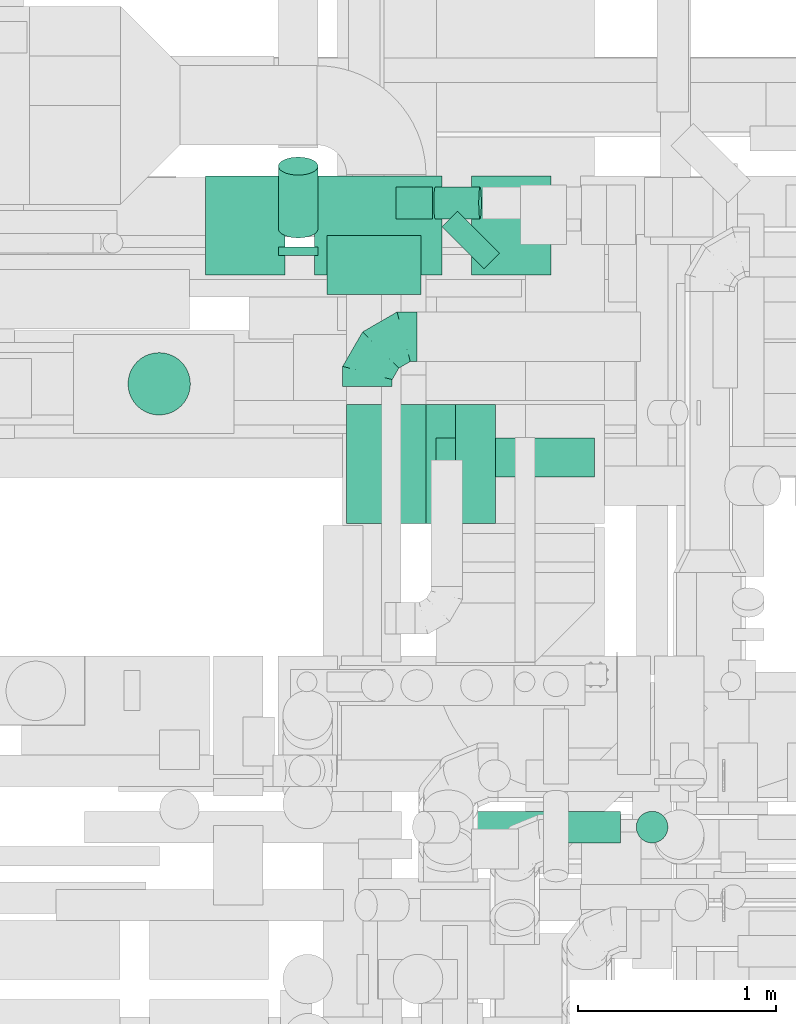
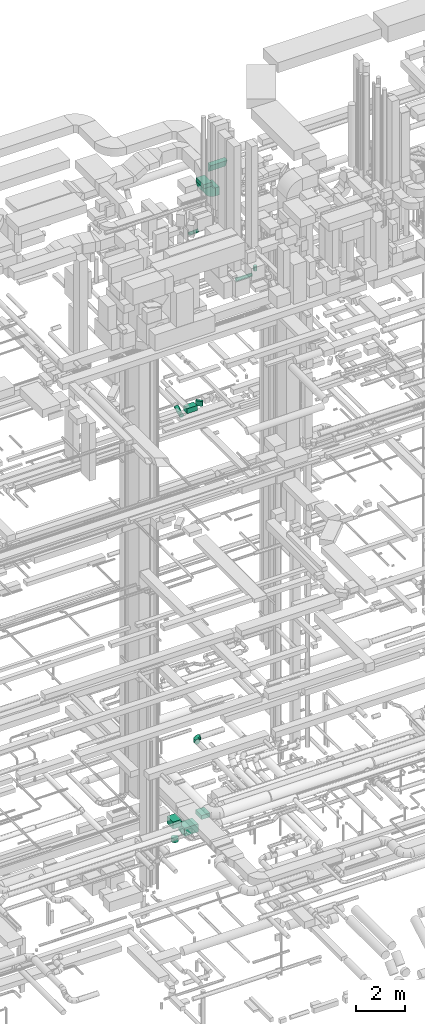
# One storey, part 192 of 337: 14 flow segments, 3 flow fittings.
"""IFC2X3 building model written with IfcOpenShell, lengths in millimetres."""

from ifc_helpers import new_model, entity, si_unit, converted_unit, derived_unit, direction, frame, frame_2d, origin, origin_2d_with_axis, place, context, subcontext, project, spatial, polyline, circle_curve, parameter, trimmed, segment, composite_curve, rectangle, circle, outline, extrude, faceted_brep, source, transform, mapped, material, type_object, type_shapes, element, save


model = new_model("IFC2X3")

# Units and contexts
model_context = context("Model", 3, precision=0.01, world=origin(), true_north=direction((6.12303176911189e-17, 1.0)))
body_context = subcontext(model_context, "Body", "Model", "MODEL_VIEW")
ifc_project = project(units=[si_unit("LENGTHUNIT", "METRE", prefix="MILLI"), si_unit("AREAUNIT", "SQUARE_METRE"), si_unit("VOLUMEUNIT", "CUBIC_METRE"), converted_unit("PLANEANGLEUNIT", "DEGREE", entity("IfcRatioMeasure", 0.0174532925199433), si_unit("PLANEANGLEUNIT", "RADIAN"), dimensions=[0, 0, 0, 0, 0, 0, 0]), si_unit("MASSUNIT", "GRAM", prefix="KILO"), derived_unit("MASSDENSITYUNIT", [(si_unit("MASSUNIT", "GRAM", prefix="KILO"), 1), (si_unit("LENGTHUNIT", "METRE"), -3)]), derived_unit("MOMENTOFINERTIAUNIT", [(si_unit("LENGTHUNIT", "METRE"), 4)]), si_unit("TIMEUNIT", "SECOND"), si_unit("FREQUENCYUNIT", "HERTZ"), si_unit("THERMODYNAMICTEMPERATUREUNIT", "DEGREE_CELSIUS"), derived_unit("THERMALTRANSMITTANCEUNIT", [(si_unit("MASSUNIT", "GRAM", prefix="KILO"), 1), (si_unit("THERMODYNAMICTEMPERATUREUNIT", "KELVIN"), -1), (si_unit("TIMEUNIT", "SECOND"), -3)]), derived_unit("VOLUMETRICFLOWRATEUNIT", [(si_unit("LENGTHUNIT", "METRE"), 3), (si_unit("TIMEUNIT", "SECOND"), -1)]), derived_unit("MASSFLOWRATEUNIT", [(si_unit("MASSUNIT", "GRAM", prefix="KILO"), 1), (si_unit("TIMEUNIT", "SECOND"), -1)]), derived_unit("ROTATIONALFREQUENCYUNIT", [(si_unit("TIMEUNIT", "SECOND"), -1)]), si_unit("ELECTRICCURRENTUNIT", "AMPERE"), si_unit("ELECTRICVOLTAGEUNIT", "VOLT"), si_unit("POWERUNIT", "WATT"), si_unit("FORCEUNIT", "NEWTON", prefix="KILO"), si_unit("ILLUMINANCEUNIT", "LUX"), si_unit("LUMINOUSFLUXUNIT", "LUMEN"), si_unit("LUMINOUSINTENSITYUNIT", "CANDELA"), derived_unit("USERDEFINED", [(si_unit("MASSUNIT", "GRAM", prefix="KILO"), -1), (si_unit("LENGTHUNIT", "METRE"), -2), (si_unit("TIMEUNIT", "SECOND"), 3), (si_unit("LUMINOUSFLUXUNIT", "LUMEN"), 1)]), derived_unit("LINEARVELOCITYUNIT", [(si_unit("LENGTHUNIT", "METRE"), 1), (si_unit("TIMEUNIT", "SECOND"), -1)]), si_unit("PRESSUREUNIT", "PASCAL"), derived_unit("USERDEFINED", [(si_unit("LENGTHUNIT", "METRE"), -2), (si_unit("MASSUNIT", "GRAM", prefix="KILO"), 1), (si_unit("TIMEUNIT", "SECOND"), -2)]), derived_unit("LINEARFORCEUNIT", [(si_unit("MASSUNIT", "GRAM", prefix="KILO"), 1), (si_unit("LENGTHUNIT", "METRE"), 1), (si_unit("TIMEUNIT", "SECOND"), -2), (si_unit("LENGTHUNIT", "METRE"), -1)]), derived_unit("PLANARFORCEUNIT", [(si_unit("MASSUNIT", "GRAM", prefix="KILO"), 1), (si_unit("LENGTHUNIT", "METRE"), 1), (si_unit("TIMEUNIT", "SECOND"), -2), (si_unit("LENGTHUNIT", "METRE"), -2)])], contexts=[model_context])

# Site, building, storey
site_placement = place(None, origin())
site = spatial("IfcSite", under=ifc_project, at=site_placement, CompositionType="ELEMENT")
building_placement = place(site_placement, origin())
building = spatial("IfcBuilding", under=site, at=building_placement, CompositionType="ELEMENT")
storey_placement = place(building_placement, origin())
storey = spatial("IfcBuildingStorey", under=building, at=storey_placement, CompositionType="ELEMENT", Elevation=0.0)

# Flow segments
duct_segment_type_1 = type_object("IfcDuctSegmentType", PredefinedType="NOTDEFINED")
flow_segment_1_placement = place(storey_placement, frame((48502.19, 15099.1, -1400.0)))
element("IfcFlowSegment", 1, at=flow_segment_1_placement, inside=storey, type_object=duct_segment_type_1, context=body_context, shape_type="SweptSolid", body=[
    extrude(rectangle(XDim=500.000000000001, YDim=399.999999999996, at=origin_2d_with_axis()), frame((200.0, 250.0, 0.0), z_axis=(0.0, 0.0, 1.0), x_axis=(0.0, -1.0, 0.0)), (0.0, 0.0, 1.0), 349.999974999914),
])
flow_segment_2_placement = place(storey_placement, frame((49052.19, 15098.96, -1950.0)))
element("IfcFlowSegment", 2, at=flow_segment_2_placement, inside=storey, type_object=duct_segment_type_1, context=body_context, shape_type="SweptSolid", body=[
    extrude(rectangle(XDim=642.936890000042, YDim=499.999999999999, at=origin_2d_with_axis()), frame((321.47, 250.0, 0.0)), (0.0, 0.0, 1.0), 400.0),
])
flow_segment_3_placement = place(storey_placement, frame((49845.13, 15098.96, -1400.0)))
element("IfcFlowSegment", 3, at=flow_segment_3_placement, inside=storey, type_object=duct_segment_type_1, context=body_context, shape_type="SweptSolid", body=[
    extrude(rectangle(XDim=399.999999999996, YDim=500.000000000001, at=origin_2d_with_axis()), frame((200.0, 250.0, 0.0)), (0.0, 0.0, 1.0), 200.000000000009),
])
flow_segment_4_placement = place(storey_placement, frame((49113.9, 14998.63, 19100.02)))
element("IfcFlowSegment", 4, at=flow_segment_4_placement, inside=storey, type_object=duct_segment_type_1, context=body_context, shape_type="SweptSolid", body=[
    extrude(rectangle(XDim=475.735931288146, YDim=300.000000000001, at=origin_2d_with_axis()), frame((237.87, 150.0, 0.0), z_axis=(0.0, 0.0, 1.0), x_axis=(-1.0, 0.0, 0.0)), (0.0, 0.0, 1.0), 249.999999999999),
])
flow_segment_5_placement = place(storey_placement, frame((49695.7, 15130.43, 19100.02)))
element("IfcFlowSegment", 5, at=flow_segment_5_placement, inside=storey, type_object=duct_segment_type_1, context=body_context, shape_type="SweptSolid", body=[
    extrude(rectangle(XDim=109.319344380098, YDim=300.000000000006, at=origin_2d_with_axis()), frame((144.72, 144.72, 0.0), z_axis=(0.0, 0.0, 1.0), x_axis=(0.707106781186449, 0.707106781186647, 0.0)), (0.0, 0.0, 1.0), 249.999999999999),
])
flow_segment_6_placement = place(storey_placement, frame((49214.76, 13844.03, 30950.0)))
element("IfcFlowSegment", 6, at=flow_segment_6_placement, inside=storey, type_object=duct_segment_type_1, context=body_context, shape_type="SweptSolid", body=[
    extrude(rectangle(XDim=399.999999999996, YDim=600.0, at=origin_2d_with_axis()), frame((200.0, 300.0, 0.0)), (0.0, 0.0, 1.0), 199.999975000022),
])
flow_segment_7_placement = place(storey_placement, frame((49764.76, 13844.03, 30400.0)))
element("IfcFlowSegment", 7, at=flow_segment_7_placement, inside=storey, type_object=duct_segment_type_1, context=body_context, shape_type="SweptSolid", body=[
    extrude(rectangle(XDim=201.68266260048, YDim=600.0, at=origin_2d_with_axis()), frame((100.84, 300.0, 0.0)), (0.0, 0.0, 1.0), 400.000000000004),
])
duct_segment_type_2 = type_object("IfcDuctSegmentType", PredefinedType="NOTDEFINED")
flow_segment_8_placement = place(storey_placement, frame((48108.57, 14389.3, -1550.0)))
element("IfcFlowSegment", 8, at=flow_segment_8_placement, inside=storey, type_object=duct_segment_type_2, context=body_context, shape_type="SweptSolid", body=[
    extrude(circle(Radius=157.5, at=origin_2d_with_axis()), frame((159.1, 159.1, 0.0), z_axis=(0.0, 0.0, 1.0), x_axis=(0.0, 1.0, 0.0)), (0.0, 0.0, 1.0), 180.000025000031),
])
flow_segment_9_placement = place(storey_placement, frame((48868.15, 15283.97, 18881.1)))
element("IfcFlowSegment", 9, at=flow_segment_9_placement, inside=storey, type_object=duct_segment_type_2, context=body_context, shape_type="SweptSolid", body=[
    extrude(circle(Radius=100.0, at=origin_2d_with_axis()), frame((101.6, 46.99, 90.7), z_axis=(0.0, 0.891006524188367, 0.453990499739548), x_axis=(-1.0, 0.0, 0.0)), (0.0, 0.0, 1.0), 355.519795607805),
])
flow_segment_10_placement = place(storey_placement, frame((48868.15, 15195.52, 18848.4)))
element("IfcFlowSegment", 10, at=flow_segment_10_placement, inside=storey, type_object=duct_segment_type_2, context=body_context, shape_type="SweptSolid", body=[
    extrude(circle(Radius=100.0, at=origin_2d_with_axis()), frame((101.6, 0.0, 101.6), z_axis=(0.0, 1.0, 0.0), x_axis=(-1.0, 0.0, 0.0)), (0.0, 0.0, 1.0), 44.6490945554549),
])
flow_segment_11_placement = place(storey_placement, frame((49842.9, 12228.45, 27058.4)))
element("IfcFlowSegment", 11, at=flow_segment_11_placement, inside=storey, type_object=duct_segment_type_2, context=body_context, shape_type="SweptSolid", body=[
    extrude(circle(Radius=80.0, at=origin_2d_with_axis()), frame((0.0, 81.6, 81.6), z_axis=(1.0, 0.0, 0.0), x_axis=(0.0, 1.0, 0.0)), (0.0, 0.0, 1.0), 753.72583002031),
])
flow_segment_12_placement = place(storey_placement, frame((50675.03, 12228.45, 27300.0)))
element("IfcFlowSegment", 12, at=flow_segment_12_placement, inside=storey, type_object=duct_segment_type_2, context=body_context, shape_type="SweptSolid", body=[
    extrude(circle(Radius=80.0, at=origin_2d_with_axis()), frame((81.6, 81.6, 0.0), z_axis=(0.0, 0.0, 1.0), x_axis=(0.0, 1.0, 0.0)), (0.0, 0.0, 1.0), 230.000000000021),
])
flow_segment_13_placement = place(storey_placement, frame((49462.56, 15380.23, 27568.4)))
element("IfcFlowSegment", 13, at=flow_segment_13_placement, inside=storey, type_object=duct_segment_type_2, context=body_context, shape_type="SweptSolid", body=[
    extrude(circle(Radius=80.0, at=origin_2d_with_axis()), frame((0.0, 81.6, 81.6), z_axis=(1.0, 0.0, 0.0), x_axis=(0.0, -1.0, 0.0)), (0.0, 0.0, 1.0), 185.338857331481),
])
flow_segment_14_placement = place(storey_placement, frame((49652.95, 15380.23, 27569.23)))
element("IfcFlowSegment", 14, at=flow_segment_14_placement, inside=storey, type_object=duct_segment_type_2, context=body_context, shape_type="SweptSolid", body=[
    extrude(circle(Radius=80.0, at=origin_2d_with_axis()), frame((8.24, 81.6, 81.32), z_axis=(0.996545753227794, 0.0, 0.0830455400587502), x_axis=(0.0, -1.0, 0.0)), (0.0, 0.0, 1.0), 227.52144208461),
])

# Flow fittings
ifc_material = material()
duct_fitting_type_1 = type_object("IfcDuctFittingType", PredefinedType="NOTDEFINED", material=ifc_material)
shared_shape_1 = source(origin(), body_context, "Body", "Brep", [
    faceted_brep([(-250.0, 0.0, -125.0), (-250.0, -32.35, -120.74), (-250.0, -62.5, -108.25), (-250.0, -88.39, -88.39), (-250.0, -108.25, -62.5), (-250.0, -120.74, -32.35), (-250.0, -125.0, 0.0), (-250.0, -120.74, 32.35), (-250.0, -108.25, 62.5), (-250.0, -88.39, 88.39), (-250.0, -62.5, 108.25), (-250.0, -32.35, 120.74), (-250.0, 0.0, 125.0), (-250.0, 32.35, 120.74), (-250.0, 62.5, 108.25), (-250.0, 88.39, 88.39), (-250.0, 108.25, 62.5), (-250.0, 120.74, 32.35), (-250.0, 125.0, 0.0), (-250.0, 120.74, -32.35), (-250.0, 108.25, -62.5), (-250.0, 88.39, -88.39), (-250.0, 62.5, -108.25), (-250.0, 32.35, -120.74), (-191.68, 32.35, 120.74), (-199.76, 62.5, 108.25), (-183.01, 0.0, 125.0), (-206.7, 88.39, 88.39), (-215.37, 120.74, 32.35), (-216.51, 125.0, 0.0), (-212.02, 108.25, 62.5), (-212.02, 108.25, -62.5), (-206.7, 88.39, -88.39), (-215.37, 120.74, -32.35), (-191.68, 32.35, -120.74), (-183.01, 0.0, -125.0), (-199.76, 62.5, -108.25), (-174.34, -32.35, -120.74), (-166.27, -62.5, -108.25), (-159.33, -88.39, -88.39), (-154.01, -108.25, -62.5), (-150.66, -120.74, -32.35), (-149.52, -125.0, 0.0), (-150.66, -120.74, 32.35), (-154.01, -108.25, 62.5), (-159.33, -88.39, 88.39), (-166.27, -62.5, 108.25), (-174.34, -32.35, 120.74), (-90.67, 90.67, 120.74), (-112.74, 112.74, 108.25), (-66.99, 66.99, 125.0), (-131.69, 131.69, 88.39), (-146.23, 146.23, 62.5), (-155.38, 155.38, 32.35), (-158.49, 158.49, 0.0), (-155.38, 155.38, -32.35), (-146.23, 146.23, -62.5), (-131.69, 131.69, -88.39), (-90.67, 90.67, -120.74), (-66.99, 66.99, -125.0), (-112.74, 112.74, -108.25), (-43.3, 43.3, -120.74), (-21.23, 21.23, -108.25), (-2.28, 2.28, -88.39), (12.26, -12.26, -62.5), (21.4, -21.4, -32.35), (24.52, -24.52, 0.0), (21.4, -21.4, 32.35), (12.26, -12.26, 62.5), (-2.28, 2.28, 88.39), (-21.23, 21.23, 108.25), (-43.3, 43.3, 120.74), (-32.35, 191.68, 120.74), (-62.5, 199.76, 108.25), (0.0, 183.01, 125.0), (-88.39, 206.7, 88.39), (-108.25, 212.02, 62.5), (-120.74, 215.37, 32.35), (-125.0, 216.51, 0.0), (-120.74, 215.37, -32.35), (-108.25, 212.02, -62.5), (-88.39, 206.7, -88.39), (-32.35, 191.68, -120.74), (0.0, 183.01, -125.0), (-62.5, 199.76, -108.25), (32.35, 174.34, -120.74), (62.5, 166.27, -108.25), (88.39, 159.33, -88.39), (108.25, 154.01, -62.5), (120.74, 150.66, -32.35), (125.0, 149.52, 0.0), (120.74, 150.66, 32.35), (108.25, 154.01, 62.5), (88.39, 159.33, 88.39), (62.5, 166.27, 108.25), (32.35, 174.34, 120.74), (-32.35, 250.0, -120.74), (-62.5, 250.0, -108.25), (-88.39, 250.0, -88.39), (-108.25, 250.0, -62.5), (-120.74, 250.0, -32.35), (-125.0, 250.0, 0.0), (-120.74, 250.0, 32.35), (-108.25, 250.0, 62.5), (-88.39, 250.0, 88.39), (-62.5, 250.0, 108.25), (-32.35, 250.0, 120.74), (0.0, 250.0, 125.0), (32.35, 250.0, 120.74), (62.5, 250.0, 108.25), (88.39, 250.0, 88.39), (108.25, 250.0, 62.5), (120.74, 250.0, 32.35), (125.0, 250.0, 0.0), (120.74, 250.0, -32.35), (108.25, 250.0, -62.5), (88.39, 250.0, -88.39), (62.5, 250.0, -108.25), (32.35, 250.0, -120.74), (0.0, 250.0, -125.0)], [[[0, 1, 2, 3, 4, 5, 6, 7, 8, 9, 10, 11, 12, 13, 14, 15, 16, 17, 18, 19, 20, 21, 22, 23]], [[24, 25, 14, 13]], [[26, 24, 13, 12]], [[14, 25, 27, 15]], [[28, 29, 18, 17]], [[30, 28, 17, 16]], [[15, 27, 30, 16]], [[20, 31, 32, 21]], [[33, 31, 20, 19]], [[18, 29, 33, 19]], [[34, 35, 0, 23]], [[36, 34, 23, 22]], [[21, 32, 36, 22]], [[1, 0, 35, 37]], [[2, 1, 37, 38]], [[38, 39, 3, 2]], [[5, 4, 40, 41]], [[6, 5, 41, 42]], [[39, 40, 4, 3]], [[6, 42, 43, 7]], [[7, 43, 44, 8]], [[8, 44, 45, 9]], [[9, 45, 46, 10]], [[10, 46, 47, 11]], [[26, 12, 11, 47]], [[48, 49, 25, 24]], [[50, 48, 24, 26]], [[27, 25, 49, 51]], [[52, 53, 28, 30]], [[51, 52, 30, 27]], [[29, 28, 53, 54]], [[55, 56, 31, 33]], [[54, 55, 33, 29]], [[32, 31, 56, 57]], [[58, 59, 35, 34]], [[60, 58, 34, 36]], [[57, 60, 36, 32]], [[37, 35, 59, 61]], [[38, 37, 61, 62]], [[39, 38, 62, 63]], [[41, 40, 64, 65]], [[42, 41, 65, 66]], [[63, 64, 40, 39]], [[43, 42, 66, 67]], [[44, 43, 67, 68]], [[68, 69, 45, 44]], [[46, 45, 69, 70]], [[47, 46, 70, 71]], [[26, 47, 71, 50]], [[72, 73, 49, 48]], [[74, 72, 48, 50]], [[51, 49, 73, 75]], [[76, 77, 53, 52]], [[75, 76, 52, 51]], [[54, 53, 77, 78]], [[79, 80, 56, 55]], [[78, 79, 55, 54]], [[57, 56, 80, 81]], [[82, 83, 59, 58]], [[84, 82, 58, 60]], [[81, 84, 60, 57]], [[61, 59, 83, 85]], [[62, 61, 85, 86]], [[63, 62, 86, 87]], [[65, 64, 88, 89]], [[66, 65, 89, 90]], [[87, 88, 64, 63]], [[67, 66, 90, 91]], [[68, 67, 91, 92]], [[92, 93, 69, 68]], [[70, 69, 93, 94]], [[71, 70, 94, 95]], [[50, 71, 95, 74]], [[96, 97, 98, 99, 100, 101, 102, 103, 104, 105, 106, 107, 108, 109, 110, 111, 112, 113, 114, 115, 116, 117, 118, 119]], [[72, 74, 107, 106]], [[73, 72, 106, 105]], [[75, 73, 105, 104]], [[77, 76, 103, 102]], [[78, 77, 102, 101]], [[75, 104, 103, 76]], [[78, 101, 100, 79]], [[79, 100, 99, 80]], [[80, 99, 98, 81]], [[84, 97, 96, 82]], [[82, 96, 119, 83]], [[84, 81, 98, 97]], [[83, 119, 118, 85]], [[85, 118, 117, 86]], [[116, 87, 86, 117]], [[88, 115, 114, 89]], [[89, 114, 113, 90]], [[115, 88, 87, 116]], [[91, 90, 113, 112]], [[92, 91, 112, 111]], [[111, 110, 93, 92]], [[95, 94, 109, 108]], [[74, 95, 108, 107]], [[110, 109, 94, 93]]]),
])
type_shapes(duct_fitting_type_1, [shared_shape_1])
flow_fitting_1_placement = place(storey_placement, frame((49319.33, 14786.17, 3000.0), z_axis=(0.0, 0.0, 1.0), x_axis=(-1.0, 0.0, 0.0)))
element("IfcFlowFitting", 15, at=flow_fitting_1_placement, inside=storey, type_object=duct_fitting_type_1, material=ifc_material, context=body_context, shape_type="MappedRepresentation", body=[
    mapped(shared_shape_1, transform((0.0, 0.0, 0.0), scale=1.0)),
])
duct_fitting_type_2 = type_object("IfcDuctFittingType", PredefinedType="NOTDEFINED", material=ifc_material)
shared_shape_2 = source(origin(), body_context, "Body", "SweptSolid", [
    extrude(outline(composite_curve([segment(polyline([(-375.0, -175.0), (25.0, -175.0)]), True, "CONTINUOUS"), segment(trimmed(circle_curve(frame_2d((175.0, -175.0), x_axis=(0.0, 1.0)), 150.0), [parameter(0.0)], [parameter(90.0000000000001)], True, "PARAMETER"), False, "CONTINUOUS"), segment(polyline([(175.0, -25.0), (175.0, 375.0)]), True, "CONTINUOUS"), segment(trimmed(circle_curve(frame_2d((175.0, -175.0), x_axis=(0.0, 1.0)), 550.0), [parameter(0.0)], [parameter(90.0)], True, "PARAMETER"), True, "CONTINUOUS")], self_intersect=False)), frame((-175.0, 175.0, -300.0), z_axis=(0.0, 0.0, 1.0), x_axis=(-1.0, 0.0, 0.0)), (0.0, 0.0, 1.0), 600.0),
])
type_shapes(duct_fitting_type_2, [shared_shape_2])
flow_fitting_2_placement = place(storey_placement, frame((49414.76, 14144.03, 30600.0), z_axis=(0.0, -1.0, 0.0), x_axis=(0.0, 0.0, -1.0)))
element("IfcFlowFitting", 16, at=flow_fitting_2_placement, inside=storey, type_object=duct_fitting_type_2, material=ifc_material, context=body_context, shape_type="MappedRepresentation", body=[
    mapped(shared_shape_2, transform((0.0, 0.0, 0.0), scale=1.0)),
])
duct_fitting_type_3 = type_object("IfcDuctFittingType", PredefinedType="NOTDEFINED", material=ifc_material)
shared_shape_3 = source(origin(), body_context, "Body", "SweptSolid", [
    extrude(outline(composite_curve([segment(polyline([(-211.61, -62.67), (188.39, -62.67)]), True, "CONTINUOUS"), segment(trimmed(circle_curve(frame_2d((338.39, -62.67), x_axis=(-0.933679897750565, 0.358108710500728)), 150.0), [parameter(0.0)], [parameter(20.9840908063534)], True, "PARAMETER"), False, "CONTINUOUS"), segment(polyline([(198.34, -8.95), (-175.13, 134.29)]), True, "CONTINUOUS"), segment(trimmed(circle_curve(frame_2d((338.39, -62.67), x_axis=(-0.933679897750565, 0.358108710500728)), 550.0), [parameter(0.0)], [parameter(20.9840908063534)], True, "PARAMETER"), True, "CONTINUOUS")], self_intersect=False)), frame((-2.15, 11.61, -400.0), z_axis=(0.0, 0.0, 1.0), x_axis=(-0.358108710500728, 0.933679897750565, 0.0)), (0.0, 0.0, 1.0), 800.0),
])
type_shapes(duct_fitting_type_3, [shared_shape_3])
flow_fitting_3_placement = place(storey_placement, frame((50065.39, 14209.05, 31630.26), z_axis=(1.0, 0.0, 0.0), x_axis=(0.0, -1.0, 0.0)))
element("IfcFlowFitting", 17, at=flow_fitting_3_placement, inside=storey, type_object=duct_fitting_type_3, material=ifc_material, context=body_context, shape_type="MappedRepresentation", body=[
    mapped(shared_shape_3, transform((0.0, 0.0, 0.0), scale=1.0)),
])

save(model, "model.ifc")
